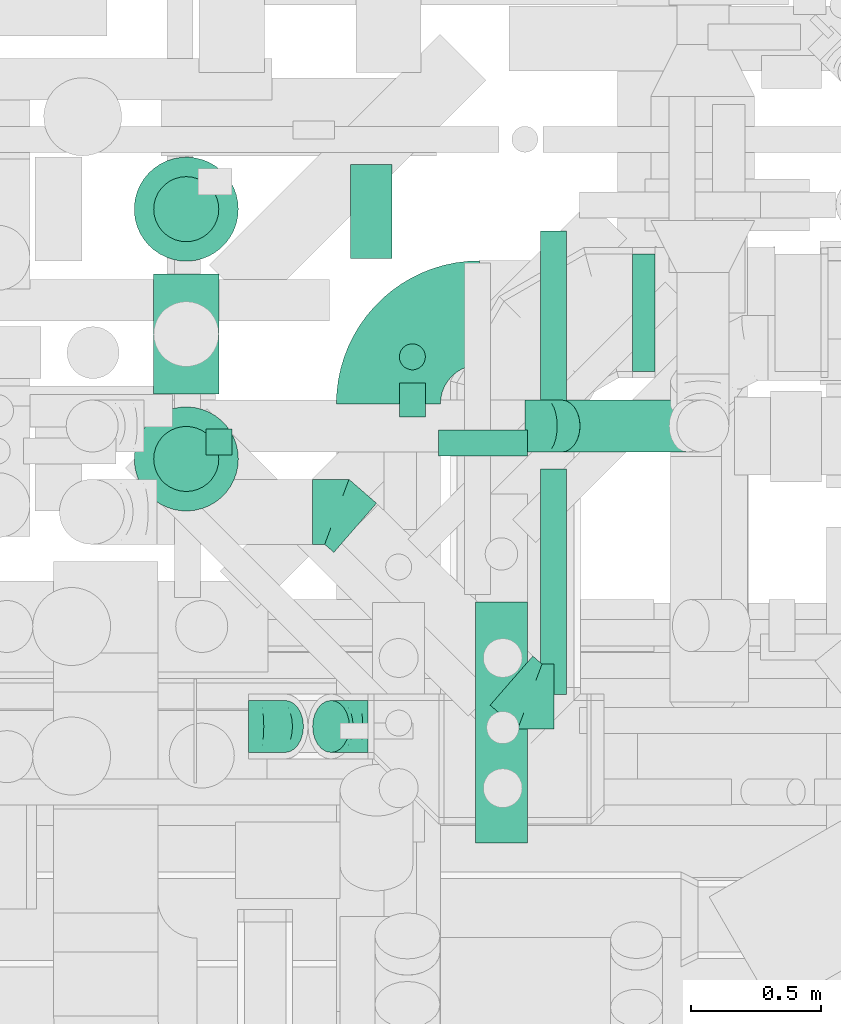
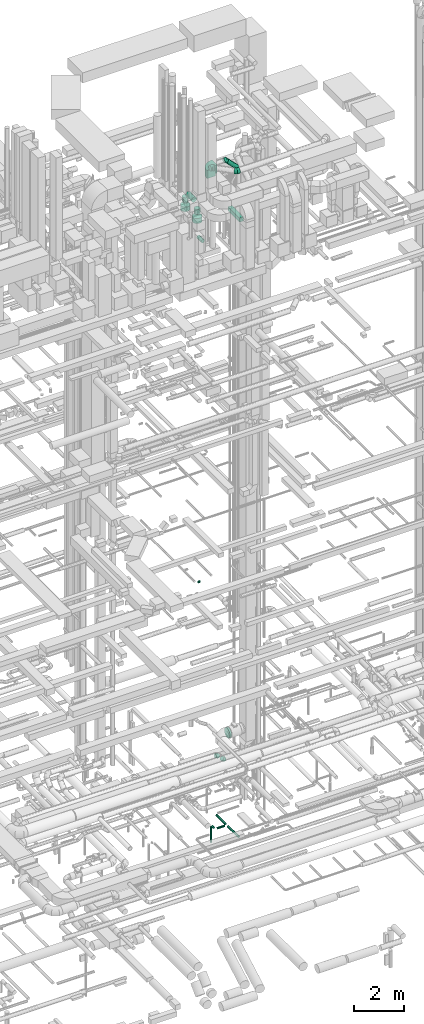
# One storey, part 229 of 337: 15 flow segments, 6 flow fittings.
"""IFC2X3 building model written with IfcOpenShell, lengths in millimetres."""

from ifc_helpers import new_model, entity, si_unit, converted_unit, derived_unit, direction, frame, frame_2d, origin, origin_2d_with_axis, place, context, subcontext, project, spatial, polyline, circle_curve, parameter, trimmed, segment, composite_curve, rectangle, circle, outline, extrude, faceted_brep, source, transform, mapped, material, type_object, type_shapes, element, save


model = new_model("IFC2X3")

# Units and contexts
model_context = context("Model", 3, precision=0.01, world=origin(), true_north=direction((6.12303176911189e-17, 1.0)))
body_context = subcontext(model_context, "Body", "Model", "MODEL_VIEW")
ifc_project = project(units=[si_unit("LENGTHUNIT", "METRE", prefix="MILLI"), si_unit("AREAUNIT", "SQUARE_METRE"), si_unit("VOLUMEUNIT", "CUBIC_METRE"), converted_unit("PLANEANGLEUNIT", "DEGREE", entity("IfcRatioMeasure", 0.0174532925199433), si_unit("PLANEANGLEUNIT", "RADIAN"), dimensions=[0, 0, 0, 0, 0, 0, 0]), si_unit("MASSUNIT", "GRAM", prefix="KILO"), derived_unit("MASSDENSITYUNIT", [(si_unit("MASSUNIT", "GRAM", prefix="KILO"), 1), (si_unit("LENGTHUNIT", "METRE"), -3)]), derived_unit("MOMENTOFINERTIAUNIT", [(si_unit("LENGTHUNIT", "METRE"), 4)]), si_unit("TIMEUNIT", "SECOND"), si_unit("FREQUENCYUNIT", "HERTZ"), si_unit("THERMODYNAMICTEMPERATUREUNIT", "DEGREE_CELSIUS"), derived_unit("THERMALTRANSMITTANCEUNIT", [(si_unit("MASSUNIT", "GRAM", prefix="KILO"), 1), (si_unit("THERMODYNAMICTEMPERATUREUNIT", "KELVIN"), -1), (si_unit("TIMEUNIT", "SECOND"), -3)]), derived_unit("VOLUMETRICFLOWRATEUNIT", [(si_unit("LENGTHUNIT", "METRE"), 3), (si_unit("TIMEUNIT", "SECOND"), -1)]), derived_unit("MASSFLOWRATEUNIT", [(si_unit("MASSUNIT", "GRAM", prefix="KILO"), 1), (si_unit("TIMEUNIT", "SECOND"), -1)]), derived_unit("ROTATIONALFREQUENCYUNIT", [(si_unit("TIMEUNIT", "SECOND"), -1)]), si_unit("ELECTRICCURRENTUNIT", "AMPERE"), si_unit("ELECTRICVOLTAGEUNIT", "VOLT"), si_unit("POWERUNIT", "WATT"), si_unit("FORCEUNIT", "NEWTON", prefix="KILO"), si_unit("ILLUMINANCEUNIT", "LUX"), si_unit("LUMINOUSFLUXUNIT", "LUMEN"), si_unit("LUMINOUSINTENSITYUNIT", "CANDELA"), derived_unit("USERDEFINED", [(si_unit("MASSUNIT", "GRAM", prefix="KILO"), -1), (si_unit("LENGTHUNIT", "METRE"), -2), (si_unit("TIMEUNIT", "SECOND"), 3), (si_unit("LUMINOUSFLUXUNIT", "LUMEN"), 1)]), derived_unit("LINEARVELOCITYUNIT", [(si_unit("LENGTHUNIT", "METRE"), 1), (si_unit("TIMEUNIT", "SECOND"), -1)]), si_unit("PRESSUREUNIT", "PASCAL"), derived_unit("USERDEFINED", [(si_unit("LENGTHUNIT", "METRE"), -2), (si_unit("MASSUNIT", "GRAM", prefix="KILO"), 1), (si_unit("TIMEUNIT", "SECOND"), -2)]), derived_unit("LINEARFORCEUNIT", [(si_unit("MASSUNIT", "GRAM", prefix="KILO"), 1), (si_unit("LENGTHUNIT", "METRE"), 1), (si_unit("TIMEUNIT", "SECOND"), -2), (si_unit("LENGTHUNIT", "METRE"), -1)]), derived_unit("PLANARFORCEUNIT", [(si_unit("MASSUNIT", "GRAM", prefix="KILO"), 1), (si_unit("LENGTHUNIT", "METRE"), 1), (si_unit("TIMEUNIT", "SECOND"), -2), (si_unit("LENGTHUNIT", "METRE"), -2)])], contexts=[model_context])

# Site, building, storey
site_placement = place(None, origin())
site = spatial("IfcSite", under=ifc_project, at=site_placement, CompositionType="ELEMENT")
building_placement = place(site_placement, origin())
building = spatial("IfcBuilding", under=site, at=building_placement, CompositionType="ELEMENT")
storey_placement = place(building_placement, origin())
storey = spatial("IfcBuildingStorey", under=building, at=storey_placement, CompositionType="ELEMENT", Elevation=0.0)

# Flow segments
duct_segment_type_1 = type_object("IfcDuctSegmentType", PredefinedType="NOTDEFINED")
flow_segment_1_placement = place(storey_placement, frame((57431.19, 9402.81, 29700.0)))
element("IfcFlowSegment", 1, at=flow_segment_1_placement, inside=storey, type_object=duct_segment_type_1, context=body_context, shape_type="SweptSolid", body=[
    extrude(rectangle(XDim=925.0, YDim=199.999999999998, at=origin_2d_with_axis()), frame((100.0, 462.5, 0.0), z_axis=(0.0, 0.0, 1.0), x_axis=(0.0, -1.0, 0.0)), (0.0, 0.0, 1.0), 199.999999999998),
])
duct_segment_type_2 = type_object("IfcDuctSegmentType", PredefinedType="NOTDEFINED")
flow_segment_2_placement = place(storey_placement, frame((57679.76, 11038.3, -1001.6)))
element("IfcFlowSegment", 2, at=flow_segment_2_placement, inside=storey, type_object=duct_segment_type_2, context=body_context, shape_type="SweptSolid", body=[
    extrude(circle(Radius=50.0, at=origin_2d_with_axis()), frame((51.6, 0.0, 51.6), z_axis=(0.0, 1.0, 0.0), x_axis=(-1.0, 0.0, 0.0)), (0.0, 0.0, 1.0), 715.931260853315),
])
flow_segment_3_placement = place(storey_placement, frame((57289.28, 10886.7, -1001.6)))
element("IfcFlowSegment", 3, at=flow_segment_3_placement, inside=storey, type_object=duct_segment_type_2, context=body_context, shape_type="SweptSolid", body=[
    extrude(circle(Radius=50.0, at=origin_2d_with_axis()), frame((0.0, 51.6, 51.6), z_axis=(1.0, 0.0, 0.0), x_axis=(0.0, 1.0, 0.0)), (0.0, 0.0, 1.0), 342.07445000001),
])
flow_segment_4_placement = place(storey_placement, frame((57679.76, 9973.56, -1001.6)))
element("IfcFlowSegment", 4, at=flow_segment_4_placement, inside=storey, type_object=duct_segment_type_2, context=body_context, shape_type="SweptSolid", body=[
    extrude(circle(Radius=50.0, at=origin_2d_with_axis()), frame((51.6, 0.0, 51.6), z_axis=(0.0, 1.0, 0.0), x_axis=(-1.0, 0.0, 0.0)), (0.0, 0.0, 1.0), 864.732350000001),
])
flow_segment_5_placement = place(storey_placement, frame((57137.68, 11038.3, -1001.6)))
element("IfcFlowSegment", 5, at=flow_segment_5_placement, inside=storey, type_object=duct_segment_type_2, context=body_context, shape_type="SweptSolid", body=[
    extrude(circle(Radius=50.0, at=origin_2d_with_axis()), frame((51.6, 0.0, 51.6), z_axis=(0.0, 1.0, 0.0), x_axis=(1.0, 0.0, 0.0)), (0.0, 0.0, 1.0), 131.767650000002),
])
flow_segment_6_placement = place(storey_placement, frame((57137.68, 11218.47, -1800.0)))
element("IfcFlowSegment", 6, at=flow_segment_6_placement, inside=storey, type_object=duct_segment_type_2, context=body_context, shape_type="SweptSolid", body=[
    extrude(circle(Radius=50.0, at=origin_2d_with_axis()), frame((51.6, 51.6, 0.0), z_axis=(0.0, 0.0, 1.0), x_axis=(-1.0, 0.0, 0.0)), (0.0, 0.0, 1.0), 750.000000000011),
])
flow_segment_7_placement = place(storey_placement, frame((56395.61, 10891.69, 11398.4)))
element("IfcFlowSegment", 7, at=flow_segment_7_placement, inside=storey, type_object=duct_segment_type_2, context=body_context, shape_type="SweptSolid", body=[
    extrude(circle(Radius=50.0, at=origin_2d_with_axis()), frame((0.0, 51.6, 51.6), z_axis=(1.0, 0.0, 0.0), x_axis=(0.0, -1.0, 0.0)), (0.0, 0.0, 1.0), 99.9999999999599),
])
flow_segment_8_placement = place(storey_placement, frame((57690.27, 10902.63, 31086.27)))
element("IfcFlowSegment", 8, at=flow_segment_8_placement, inside=storey, type_object=duct_segment_type_2, context=body_context, shape_type="SweptSolid", body=[
    extrude(circle(Radius=100.0, at=origin_2d_with_axis()), frame((556.19, 101.6, 72.31), z_axis=(-0.70710678118656, 0.0, 0.707106781186535), x_axis=(0.0, 1.0, 0.0)), (0.0, 0.0, 1.0), 684.314575050776),
])
flow_segment_9_placement = place(storey_placement, frame((56193.9, 11127.69, 30024.23)))
element("IfcFlowSegment", 9, at=flow_segment_9_placement, inside=storey, type_object=duct_segment_type_2, context=body_context, shape_type="SweptSolid", body=[
    extrude(circle(Radius=125.0, at=origin_2d_with_axis()), frame((126.6, 0.0, 126.6), z_axis=(0.0, 1.0, 0.0), x_axis=(-1.0, 0.0, 0.0)), (0.0, 0.0, 1.0), 459.680704037181),
])
flow_segment_10_placement = place(storey_placement, frame((56118.9, 10676.1, 29265.0)))
element("IfcFlowSegment", 10, at=flow_segment_10_placement, inside=storey, type_object=duct_segment_type_2, context=body_context, shape_type="SweptSolid", body=[
    extrude(circle(Radius=200.0, at=origin_2d_with_axis()), frame((201.6, 201.6, 0.0)), (0.0, 0.0, 1.0), 245.824520084263),
])
flow_segment_11_placement = place(storey_placement, frame((56118.9, 11635.78, 29265.0)))
element("IfcFlowSegment", 11, at=flow_segment_11_placement, inside=storey, type_object=duct_segment_type_2, context=body_context, shape_type="SweptSolid", body=[
    extrude(circle(Radius=200.0, at=origin_2d_with_axis()), frame((201.6, 201.6, 0.0)), (0.0, 0.0, 1.0), 225.824520084267),
])
flow_segment_12_placement = place(storey_placement, frame((56193.9, 11710.78, 29640.82)))
element("IfcFlowSegment", 12, at=flow_segment_12_placement, inside=storey, type_object=duct_segment_type_2, context=body_context, shape_type="SweptSolid", body=[
    extrude(circle(Radius=125.0, at=origin_2d_with_axis()), frame((126.6, 126.6, 0.0)), (0.0, 0.0, 1.0), 260.000000000002),
])
flow_segment_13_placement = place(storey_placement, frame((56193.9, 10751.1, 29660.82)))
element("IfcFlowSegment", 13, at=flow_segment_13_placement, inside=storey, type_object=duct_segment_type_2, context=body_context, shape_type="SweptSolid", body=[
    extrude(circle(Radius=125.0, at=origin_2d_with_axis()), frame((126.6, 126.6, 0.0)), (0.0, 0.0, 1.0), 240.000000000002),
])
flow_segment_14_placement = place(storey_placement, frame((56950.06, 11648.11, 27468.4)))
element("IfcFlowSegment", 14, at=flow_segment_14_placement, inside=storey, type_object=duct_segment_type_2, context=body_context, shape_type="SweptSolid", body=[
    extrude(circle(Radius=80.0, at=origin_2d_with_axis()), frame((81.6, 0.0, 81.6), z_axis=(0.0, 1.0, 0.0), x_axis=(1.0, 0.0, 0.0)), (0.0, 0.0, 1.0), 360.000000000009),
])
flow_segment_15_placement = place(storey_placement, frame((58035.12, 11212.98, 2939.23)))
element("IfcFlowSegment", 15, at=flow_segment_15_placement, inside=storey, type_object=duct_segment_type_2, context=body_context, shape_type="SweptSolid", body=[
    extrude(circle(Radius=225.0, at=origin_2d_with_axis()), frame((0.0, 226.6, 226.6), z_axis=(1.0, 0.0, 0.0), x_axis=(0.0, -1.0, 0.0)), (0.0, 0.0, 1.0), 87.0464963212918),
])

# Flow fittings
ifc_material = material()
duct_fitting_type_1 = type_object("IfcDuctFittingType", PredefinedType="NOTDEFINED", material=ifc_material)
shared_shape_1 = source(origin(), body_context, "Body", "Brep", [
    faceted_brep([(-82.84, 0.0, -100.0), (-82.84, -25.88, -96.59), (-82.84, -50.0, -86.6), (-82.84, -70.71, -70.71), (-82.84, -86.6, -50.0), (-82.84, -96.59, -25.88), (-82.84, -100.0, 0.0), (-82.84, -96.59, 25.88), (-82.84, -86.6, 50.0), (-82.84, -70.71, 70.71), (-82.84, -50.0, 86.6), (-82.84, -25.88, 96.59), (-82.84, 0.0, 100.0), (-82.84, 25.88, 96.59), (-82.84, 50.0, 86.6), (-82.84, 70.71, 70.71), (-82.84, 86.6, 50.0), (-82.84, 96.59, 25.88), (-82.84, 100.0, 0.0), (-82.84, 96.59, -25.88), (-82.84, 86.6, -50.0), (-82.84, 70.71, -70.71), (-82.84, 50.0, -86.6), (-82.84, 25.88, -96.59), (-10.72, 25.88, 96.59), (-20.71, 50.0, 86.6), (0.0, 0.0, 100.0), (-29.29, 70.71, 70.71), (-35.87, 86.6, 50.0), (-40.01, 96.59, 25.88), (-41.42, 100.0, 0.0), (-40.01, 96.59, -25.88), (-35.87, 86.6, -50.0), (-29.29, 70.71, -70.71), (-10.72, 25.88, -96.59), (0.0, 0.0, -100.0), (-20.71, 50.0, -86.6), (10.72, -25.88, -96.59), (20.71, -50.0, -86.6), (29.29, -70.71, -70.71), (35.87, -86.6, -50.0), (40.01, -96.59, -25.88), (41.42, -100.0, 0.0), (40.01, -96.59, 25.88), (35.87, -86.6, 50.0), (29.29, -70.71, 70.71), (20.71, -50.0, 86.6), (10.72, -25.88, 96.59), (58.58, 58.58, 100.0), (40.28, 76.88, 96.59), (23.22, 93.93, 86.6), (8.58, 108.58, 70.71), (-2.66, 119.82, 50.0), (-9.72, 126.88, 25.88), (-12.13, 129.29, 0.0), (-9.72, 126.88, -25.88), (-2.66, 119.82, -50.0), (8.58, 108.58, -70.71), (23.22, 93.93, -86.6), (40.28, 76.88, -96.59), (58.58, 58.58, -100.0), (76.88, 40.28, -96.59), (93.93, 23.22, -86.6), (108.58, 8.58, -70.71), (119.82, -2.66, -50.0), (126.88, -9.72, -25.88), (129.29, -12.13, 0.0), (126.88, -9.72, 25.88), (119.82, -2.66, 50.0), (108.58, 8.58, 70.71), (93.93, 23.22, 86.6), (76.88, 40.28, 96.59)], [[[0, 1, 2, 3, 4, 5, 6, 7, 8, 9, 10, 11, 12, 13, 14, 15, 16, 17, 18, 19, 20, 21, 22, 23]], [[24, 25, 14, 13]], [[26, 24, 13, 12]], [[14, 25, 27, 15]], [[28, 29, 17, 16]], [[28, 16, 15, 27]], [[30, 18, 17, 29]], [[31, 32, 20, 19]], [[30, 31, 19, 18]], [[32, 33, 21, 20]], [[34, 35, 0, 23]], [[36, 34, 23, 22]], [[33, 36, 22, 21]], [[1, 0, 35, 37]], [[2, 1, 37, 38]], [[38, 39, 3, 2]], [[5, 4, 40, 41]], [[6, 5, 41, 42]], [[39, 40, 4, 3]], [[6, 42, 43, 7]], [[7, 43, 44, 8]], [[8, 44, 45, 9]], [[9, 45, 46, 10]], [[10, 46, 47, 11]], [[26, 12, 11, 47]], [[24, 26, 48, 49]], [[25, 24, 49, 50]], [[27, 25, 50, 51]], [[29, 28, 52, 53]], [[30, 29, 53, 54]], [[51, 52, 28, 27]], [[30, 54, 55, 31]], [[31, 55, 56, 32]], [[57, 33, 32, 56]], [[36, 58, 59, 34]], [[34, 59, 60, 35]], [[58, 36, 33, 57]], [[35, 60, 61, 37]], [[37, 61, 62, 38]], [[63, 39, 38, 62]], [[40, 64, 65, 41]], [[41, 65, 66, 42]], [[64, 40, 39, 63]], [[43, 42, 66, 67]], [[44, 43, 67, 68]], [[68, 69, 45, 44]], [[47, 46, 70, 71]], [[26, 47, 71, 48]], [[69, 70, 46, 45]], [[59, 58, 57, 56, 55, 54, 53, 52, 51, 50, 49, 48, 71, 70, 69, 68, 67, 66, 65, 64, 63, 62, 61, 60]]]),
])
type_shapes(duct_fitting_type_1, [shared_shape_1])
flow_fitting_1_placement = place(storey_placement, frame((57703.99, 11004.22, 31701.04), z_axis=(0.0, -1.0, 0.0), x_axis=(-0.707106781186559, 0.0, 0.707106781186536)))
element("IfcFlowFitting", 16, at=flow_fitting_1_placement, inside=storey, type_object=duct_fitting_type_1, material=ifc_material, context=body_context, shape_type="MappedRepresentation", body=[
    mapped(shared_shape_1, transform((0.0, 0.0, 0.0), scale=1.0)),
])
duct_fitting_type_2 = type_object("IfcDuctFittingType", PredefinedType="NOTDEFINED", material=ifc_material)
shared_shape_2 = source(origin(), body_context, "Body", "Brep", [
    faceted_brep([(-82.84, 0.0, -100.0), (-82.84, -25.88, -96.59), (-82.84, -50.0, -86.6), (-82.84, -70.71, -70.71), (-82.84, -86.6, -50.0), (-82.84, -96.59, -25.88), (-82.84, -100.0, 0.0), (-82.84, -96.59, 25.88), (-82.84, -86.6, 50.0), (-82.84, -70.71, 70.71), (-82.84, -50.0, 86.6), (-82.84, -25.88, 96.59), (-82.84, 0.0, 100.0), (-82.84, 25.88, 96.59), (-82.84, 50.0, 86.6), (-82.84, 70.71, 70.71), (-82.84, 86.6, 50.0), (-82.84, 96.59, 25.88), (-82.84, 100.0, 0.0), (-82.84, 96.59, -25.88), (-82.84, 86.6, -50.0), (-82.84, 70.71, -70.71), (-82.84, 50.0, -86.6), (-82.84, 25.88, -96.59), (-48.21, 25.88, 96.59), (-53.01, 50.0, 86.6), (-43.06, 0.0, 100.0), (-57.13, 70.71, 70.71), (-62.27, 96.59, 25.88), (-62.95, 100.0, 0.0), (-60.29, 86.6, 50.0), (-60.29, 86.6, -50.0), (-57.13, 70.71, -70.71), (-62.27, 96.59, -25.88), (-48.21, 25.88, -96.59), (-43.06, 0.0, -100.0), (-53.01, 50.0, -86.6), (-37.91, -25.88, -96.59), (-33.11, -50.0, -86.6), (-29.0, -70.71, -70.71), (-25.83, -86.6, -50.0), (-23.85, -96.59, -25.88), (-23.17, -100.0, 0.0), (-23.85, -96.59, 25.88), (-25.83, -86.6, 50.0), (-29.0, -70.71, 70.71), (-33.11, -50.0, 86.6), (-37.91, -25.88, 96.59), (15.79, 52.39, 96.59), (2.13, 72.84, 86.6), (30.45, 30.45, 100.0), (-9.61, 90.39, 70.71), (-18.61, 103.87, 50.0), (-24.27, 112.34, 25.88), (-26.2, 115.22, 0.0), (-24.27, 112.34, -25.88), (-18.61, 103.87, -50.0), (-9.61, 90.39, -70.71), (15.79, 52.39, -96.59), (30.45, 30.45, -100.0), (2.13, 72.84, -86.6), (45.11, 8.51, -96.59), (58.77, -11.94, -86.6), (70.5, -29.5, -70.71), (79.5, -42.97, -50.0), (85.16, -51.44, -25.88), (87.09, -54.33, 0.0), (85.16, -51.44, 25.88), (79.5, -42.97, 50.0), (70.5, -29.5, 70.71), (58.77, -11.94, 86.6), (45.11, 8.51, 96.59), (58.58, 58.58, 100.0), (40.28, 76.88, 96.59), (23.22, 93.93, 86.6), (8.58, 108.58, 70.71), (-2.66, 119.82, 50.0), (-9.72, 126.88, 25.88), (-12.13, 129.29, 0.0), (-9.72, 126.88, -25.88), (-2.66, 119.82, -50.0), (8.58, 108.58, -70.71), (23.22, 93.93, -86.6), (40.28, 76.88, -96.59), (58.58, 58.58, -100.0), (76.88, 40.28, -96.59), (93.93, 23.22, -86.6), (108.58, 8.58, -70.71), (119.82, -2.66, -50.0), (126.88, -9.72, -25.88), (129.29, -12.13, 0.0), (126.88, -9.72, 25.88), (119.82, -2.66, 50.0), (108.58, 8.58, 70.71), (93.93, 23.22, 86.6), (76.88, 40.28, 96.59)], [[[0, 1, 2, 3, 4, 5, 6, 7, 8, 9, 10, 11, 12, 13, 14, 15, 16, 17, 18, 19, 20, 21, 22, 23]], [[24, 25, 14, 13]], [[26, 24, 13, 12]], [[14, 25, 27, 15]], [[28, 29, 18, 17]], [[30, 28, 17, 16]], [[15, 27, 30, 16]], [[20, 31, 32, 21]], [[33, 31, 20, 19]], [[18, 29, 33, 19]], [[34, 35, 0, 23]], [[36, 34, 23, 22]], [[32, 36, 22, 21]], [[2, 1, 37, 38]], [[3, 2, 38, 39]], [[0, 35, 37, 1]], [[5, 4, 40, 41]], [[6, 5, 41, 42]], [[39, 40, 4, 3]], [[6, 42, 43, 7]], [[7, 43, 44, 8]], [[8, 44, 45, 9]], [[10, 46, 47, 11]], [[11, 47, 26, 12]], [[9, 45, 46, 10]], [[48, 49, 25, 24]], [[50, 48, 24, 26]], [[27, 25, 49, 51]], [[52, 53, 28, 30]], [[51, 52, 30, 27]], [[29, 28, 53, 54]], [[55, 56, 31, 33]], [[54, 55, 33, 29]], [[32, 31, 56, 57]], [[58, 59, 35, 34]], [[60, 58, 34, 36]], [[57, 60, 36, 32]], [[37, 35, 59, 61]], [[38, 37, 61, 62]], [[39, 38, 62, 63]], [[41, 40, 64, 65]], [[42, 41, 65, 66]], [[63, 64, 40, 39]], [[43, 42, 66, 67]], [[44, 43, 67, 68]], [[68, 69, 45, 44]], [[46, 45, 69, 70]], [[47, 46, 70, 71]], [[26, 47, 71, 50]], [[48, 50, 72, 73]], [[49, 48, 73, 74]], [[51, 49, 74, 75]], [[53, 52, 76, 77]], [[54, 53, 77, 78]], [[51, 75, 76, 52]], [[54, 78, 79, 55]], [[55, 79, 80, 56]], [[56, 80, 81, 57]], [[60, 82, 83, 58]], [[58, 83, 84, 59]], [[60, 57, 81, 82]], [[59, 84, 85, 61]], [[61, 85, 86, 62]], [[62, 86, 87, 63]], [[64, 88, 89, 65]], [[65, 89, 90, 66]], [[63, 87, 88, 64]], [[67, 66, 90, 91]], [[68, 67, 91, 92]], [[69, 68, 92, 93]], [[71, 70, 94, 95]], [[50, 71, 95, 72]], [[93, 94, 70, 69]], [[83, 82, 81, 80, 79, 78, 77, 76, 75, 74, 73, 72, 95, 94, 93, 92, 91, 90, 89, 88, 87, 86, 85, 84]]]),
])
type_shapes(duct_fitting_type_2, [shared_shape_2])
for number, where, z_axis, x_axis in (
    (17, (56641.53, 9850.0, 3520.0), (0.0, -1.0, 0.0), (-0.707106630945556, 0.0, 0.707106931427508)),
    (18, (56935.33, 9850.0, 3226.2), (0.0, -1.0, 0.0), (0.707106630945521, 0.0, -0.707106931427542)),
):
    element("IfcFlowFitting", number, at=place(storey_placement, frame(where, z_axis=z_axis, x_axis=x_axis)), inside=storey, type_object=duct_fitting_type_2, material=ifc_material, context=body_context, shape_type="MappedRepresentation", body=[
        mapped(shared_shape_2, transform((0.0, 0.0, 0.0), scale=1.0)),
    ])
duct_fitting_type_3 = type_object("IfcDuctFittingType", PredefinedType="NOTDEFINED", material=ifc_material)
shared_shape_3 = source(origin(), body_context, "Body", "Brep", [
    faceted_brep([(-93.47, 0.0, -125.0), (-93.47, -32.35, -120.74), (-93.47, -62.5, -108.25), (-93.47, -88.39, -88.39), (-93.47, -108.25, -62.5), (-93.47, -120.74, -32.35), (-93.47, -125.0, 0.0), (-93.47, -120.74, 32.35), (-93.47, -108.25, 62.5), (-93.47, -88.39, 88.39), (-93.47, -62.5, 108.25), (-93.47, -32.35, 120.74), (-93.47, 0.0, 125.0), (-93.47, 32.35, 120.74), (-93.47, 62.5, 108.25), (-93.47, 88.39, 88.39), (-93.47, 108.25, 62.5), (-93.47, 120.74, 32.35), (-93.47, 125.0, 0.0), (-93.47, 120.74, -32.35), (-93.47, 108.25, -62.5), (-93.47, 88.39, -88.39), (-93.47, 62.5, -108.25), (-93.47, 32.35, -120.74), (-12.1, 32.35, 120.74), (-23.37, 62.5, 108.25), (0.0, 0.0, 125.0), (-33.05, 88.39, 88.39), (-40.47, 108.25, 62.5), (-45.14, 120.74, 32.35), (-46.74, 125.0, 0.0), (-45.14, 120.74, -32.35), (-40.47, 108.25, -62.5), (-33.05, 88.39, -88.39), (-12.1, 32.35, -120.74), (0.0, 0.0, -125.0), (-23.37, 62.5, -108.25), (12.1, -32.35, -120.74), (23.37, -62.5, -108.25), (33.05, -88.39, -88.39), (40.47, -108.25, -62.5), (45.14, -120.74, -32.35), (46.74, -125.0, 0.0), (45.14, -120.74, 32.35), (40.47, -108.25, 62.5), (33.05, -88.39, 88.39), (23.37, -62.5, 108.25), (12.1, -32.35, 120.74), (70.54, 61.32, 125.0), (49.32, 85.74, 120.74), (29.54, 108.49, 108.25), (12.56, 128.03, 88.39), (-0.48, 143.02, 62.5), (-8.67, 152.45, 32.35), (-11.46, 155.66, 0.0), (-8.67, 152.45, -32.35), (-0.48, 143.02, -62.5), (12.56, 128.03, -88.39), (29.54, 108.49, -108.25), (49.32, 85.74, -120.74), (70.54, 61.32, -125.0), (91.77, 36.91, -120.74), (111.55, 14.15, -108.25), (128.53, -5.38, -88.39), (141.56, -20.38, -62.5), (149.76, -29.8, -32.35), (152.55, -33.02, 0.0), (149.76, -29.8, 32.35), (141.56, -20.38, 62.5), (128.53, -5.38, 88.39), (111.55, 14.15, 108.25), (91.77, 36.91, 120.74)], [[[0, 1, 2, 3, 4, 5, 6, 7, 8, 9, 10, 11, 12, 13, 14, 15, 16, 17, 18, 19, 20, 21, 22, 23]], [[24, 25, 14, 13]], [[26, 24, 13, 12]], [[14, 25, 27, 15]], [[28, 29, 17, 16]], [[28, 16, 15, 27]], [[30, 18, 17, 29]], [[31, 32, 20, 19]], [[30, 31, 19, 18]], [[32, 33, 21, 20]], [[34, 35, 0, 23]], [[36, 34, 23, 22]], [[33, 36, 22, 21]], [[1, 0, 35, 37]], [[2, 1, 37, 38]], [[38, 39, 3, 2]], [[5, 4, 40, 41]], [[6, 5, 41, 42]], [[39, 40, 4, 3]], [[6, 42, 43, 7]], [[7, 43, 44, 8]], [[8, 44, 45, 9]], [[9, 45, 46, 10]], [[10, 46, 47, 11]], [[26, 12, 11, 47]], [[24, 26, 48, 49]], [[25, 24, 49, 50]], [[27, 25, 50, 51]], [[29, 28, 52, 53]], [[30, 29, 53, 54]], [[51, 52, 28, 27]], [[30, 54, 55, 31]], [[31, 55, 56, 32]], [[57, 33, 32, 56]], [[36, 58, 59, 34]], [[34, 59, 60, 35]], [[58, 36, 33, 57]], [[35, 60, 61, 37]], [[37, 61, 62, 38]], [[63, 39, 38, 62]], [[40, 64, 65, 41]], [[41, 65, 66, 42]], [[64, 40, 39, 63]], [[43, 42, 66, 67]], [[44, 43, 67, 68]], [[68, 69, 45, 44]], [[47, 46, 70, 71]], [[26, 47, 71, 48]], [[69, 70, 46, 45]], [[59, 58, 57, 56, 55, 54, 53, 52, 51, 50, 49, 48, 71, 70, 69, 68, 67, 66, 65, 64, 63, 62, 61, 60]]]),
])
type_shapes(duct_fitting_type_3, [shared_shape_3])
for number, where, z_axis, x_axis in (
    (19, (56898.98, 10674.5, 31800.0), (0.0, 0.0, 1.0), (-0.754709580222769, 0.656059028990511, 0.0)),
    (20, (57640.61, 9964.73, 31800.0), (0.0, 0.0, 1.0), (0.75470958022276, -0.656059028990521, 0.0)),
):
    element("IfcFlowFitting", number, at=place(storey_placement, frame(where, z_axis=z_axis, x_axis=x_axis)), inside=storey, type_object=duct_fitting_type_3, material=ifc_material, context=body_context, shape_type="MappedRepresentation", body=[
        mapped(shared_shape_3, transform((0.0, 0.0, 0.0), scale=1.0)),
    ])
duct_fitting_type_4 = type_object("IfcDuctFittingType", PredefinedType="NOTDEFINED", material=ifc_material)
shared_shape_4 = source(origin(), body_context, "Body", "SweptSolid", [
    extrude(outline(composite_curve([segment(polyline([(-375.0, -175.0), (25.0, -175.0)]), True, "CONTINUOUS"), segment(trimmed(circle_curve(frame_2d((175.0, -175.0), x_axis=(0.0, 1.0)), 150.0), [parameter(0.0)], [parameter(90.0)], True, "PARAMETER"), False, "CONTINUOUS"), segment(polyline([(175.0, -25.0), (175.0, 375.0)]), True, "CONTINUOUS"), segment(trimmed(circle_curve(frame_2d((175.0, -175.0), x_axis=(0.0, 1.0)), 550.0), [parameter(0.0)], [parameter(90.0)], True, "PARAMETER"), True, "CONTINUOUS")], self_intersect=False)), frame((-175.0, 175.0, -200.0), z_axis=(0.0, 0.0, 1.0), x_axis=(-1.0, 0.0, 0.0)), (0.0, 0.0, 1.0), 400.0),
])
type_shapes(duct_fitting_type_4, [shared_shape_4])
flow_fitting_2_placement = place(storey_placement, frame((57097.0, 11439.32, 31200.0), z_axis=(0.0, 0.0, 1.0), x_axis=(-1.0, 0.0, 0.0)))
element("IfcFlowFitting", 21, at=flow_fitting_2_placement, inside=storey, type_object=duct_fitting_type_4, material=ifc_material, context=body_context, shape_type="MappedRepresentation", body=[
    mapped(shared_shape_4, transform((0.0, 0.0, 0.0), scale=1.0)),
])

save(model, "model.ifc")
